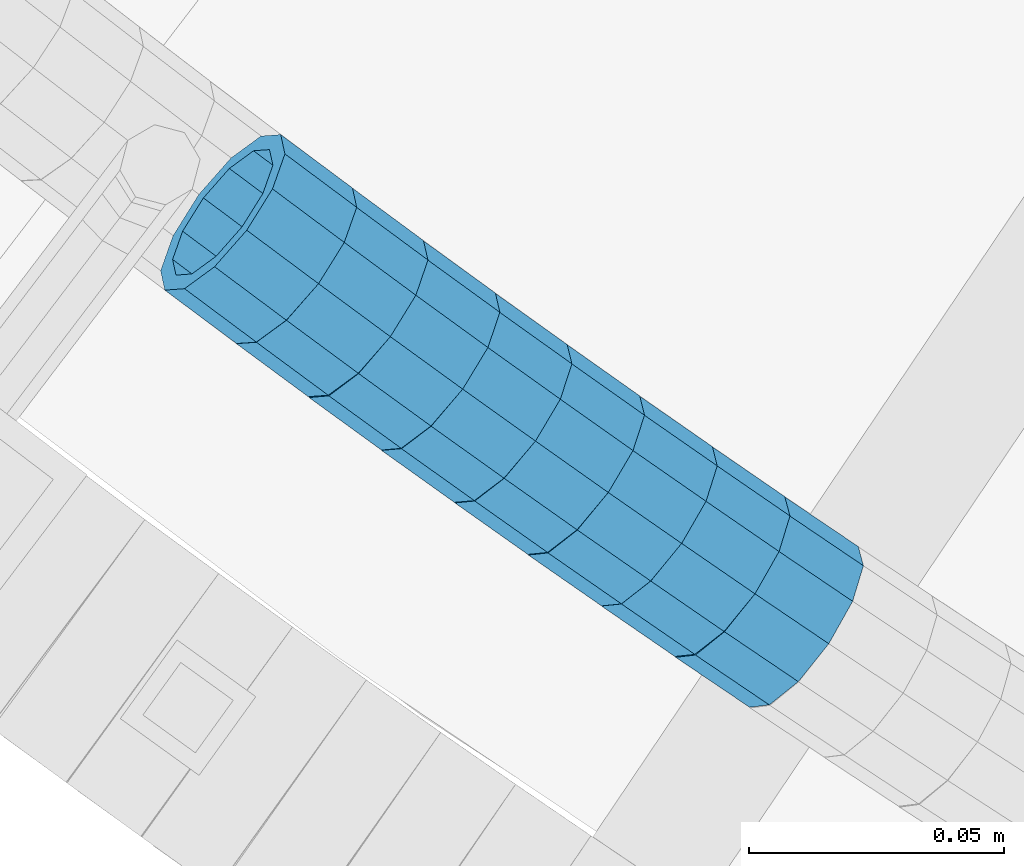
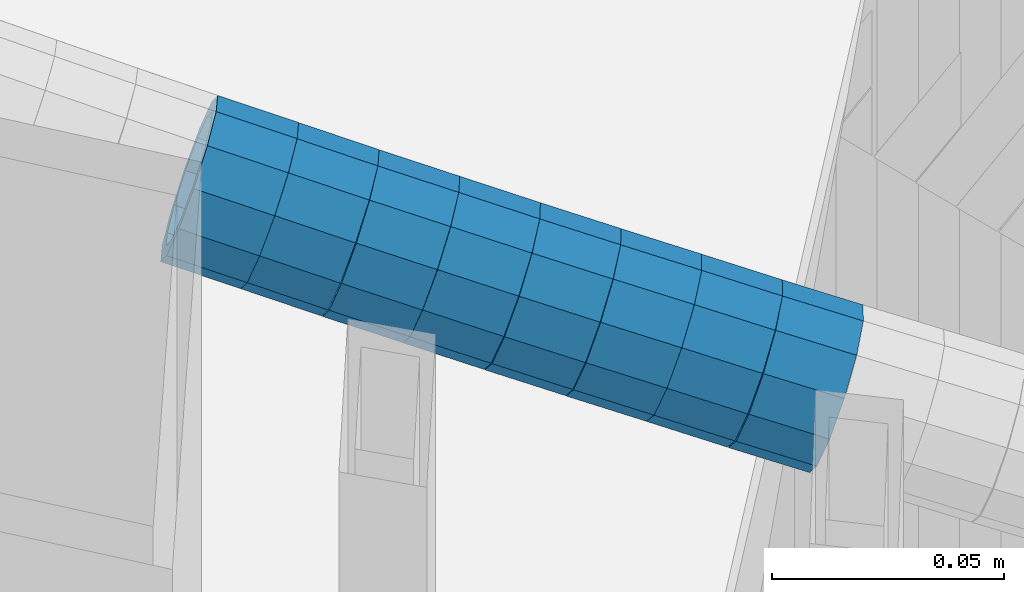
# One storey, part 644 of 975: 8 beams.
"""IFC2X3 building model written with IfcOpenShell, lengths in millimetres."""

from ifc_helpers import new_model, si_unit, frame, origin_with_axes, place, context, subcontext, project, spatial, faceted_brep, material, type_object, element, save


model = new_model("IFC2X3")

# Units and contexts
model_context = context("Model", 3, precision=1e-05, world=origin_with_axes())
body_context = subcontext(model_context, "Body", "Model", "MODEL_VIEW")
ifc_project = project(units=[si_unit("LENGTHUNIT", "METRE", prefix="MILLI"), si_unit("AREAUNIT", "SQUARE_METRE"), si_unit("VOLUMEUNIT", "CUBIC_METRE"), si_unit("MASSUNIT", "GRAM", prefix="KILO"), si_unit("TIMEUNIT", "SECOND"), si_unit("PLANEANGLEUNIT", "RADIAN"), si_unit("SOLIDANGLEUNIT", "STERADIAN"), si_unit("THERMODYNAMICTEMPERATUREUNIT", "DEGREE_CELSIUS"), si_unit("LUMINOUSINTENSITYUNIT", "LUMEN")], contexts=[model_context])

# Site, building, storey
site_placement = place(None, origin_with_axes())
site = spatial("IfcSite", under=ifc_project, at=site_placement, CompositionType="ELEMENT")
building_placement = place(site_placement, origin_with_axes())
building = spatial("IfcBuilding", under=site, at=building_placement, Name="Undefined", CompositionType="ELEMENT")
storey_placement = place(building_placement, origin_with_axes())
storey = spatial("IfcBuildingStorey", under=building, at=storey_placement, Name="Undefined", CompositionType="ELEMENT", Elevation=0.0)

# Beams
ifc_material = material()
beam_type = type_object("IfcBeamType", PredefinedType="NOTDEFINED")
beam_1_placement = place(storey_placement, frame((33062.1842327912, 1173.21661137513, 4796.37870485377), z_axis=(0.597266145727394, 0.802043110542036, 1.75857167050708e-10), x_axis=(0.762942780876697, -0.568148878908228, -0.308423676950159)))
element("IfcBeam", 1, at=beam_1_placement, inside=storey, type_object=beam_type, material=ifc_material, Name="WALL", context=body_context, shape_type="Brep", body=[
    faceted_brep([(-2.1246523829177e-07, -15.367000000002, 0.0), (-1.83998054126278e-07, -13.3082123799541, 7.68350000000009), (18.4753890351749, -13.3082123799613, 7.6835000000101), (18.4753890351676, -15.3670000000056, 0.0), (-1.06232619145885e-07, -7.68349999999919, 13.3082123799559), (18.4753890351822, -7.6835000000101, 13.3082123799686), (-3.63797880709171e-12, 3.63797880709171e-12, 15.3670000000002), (18.4753890351967, -1.2732925824821e-11, 15.3670000000238), (1.06225343188271e-07, 7.68350000000646, 13.3082123799559), (18.475389035204, 7.68349999998463, 13.3082123799832), (1.8399441614747e-07, 13.308212379965, 7.68350000000009), (18.4753890352004, 13.3082123799395, 7.68350000002465), (2.12461600312963e-07, 15.3670000000093, 0.0), (18.4753890351967, 15.3669999999838, 2.5465851649642e-11), (1.8399441614747e-07, 13.308212379965, -7.68350000000009), (18.4753890351894, 13.3082123799413, -7.68349999998463), (1.06225343188271e-07, 7.68350000000646, -13.3082123799559), (18.4753890351749, 7.68349999998827, -13.3082123799468), (-3.63797880709171e-12, 3.63797880709171e-12, -15.3670000000002), (18.4753890351676, -1.09139364212751e-11, -15.3669999999947), (-1.06232619145885e-07, -7.68349999999919, -13.3082123799559), (18.4753890351676, -7.68350000000646, -13.3082123799577), (-1.83998054126278e-07, -13.3082123799541, -7.68350000000009), (18.4753890351567, -13.3082123799613, -7.68350000000282), (-2.63386027654633e-07, -19.0500000000029, 0.0), (-2.28097633225843e-07, -16.4977839420972, -9.52499999999964), (18.4753890351567, -16.4977839420972, -9.52500000000873), (18.4753890351676, -19.0500000000065, 0.0), (-1.31691194837913e-07, -9.52500000000146, -16.4977839420935), (18.475389035164, -9.52500000000873, -16.4977839420972), (-3.63797880709171e-12, 3.63797880709171e-12, -19.0500000000002), (18.475389035164, -9.09494701772928e-12, -19.0499999999993), (1.31687556859106e-07, 9.52500000000509, -16.4977839420935), (18.4753890351822, 9.5249999999869, -16.497783942079), (2.28097633225843e-07, 16.4977839421044, -9.52499999999964), (18.4753890351931, 16.497783942079, -9.52499999997963), (2.63382389675826e-07, 19.0500000000138, 0.0), (18.475389035204, 19.0499999999847, 2.91038304567337e-11), (2.28097633225843e-07, 16.4977839421044, 9.52499999999964), (18.4753890352113, 16.4977839420753, 9.5250000000342), (1.31687556859106e-07, 9.52500000000509, 16.4977839420935), (18.475389035204, 9.52499999998327, 16.4977839421226), (-3.63797880709171e-12, 3.63797880709171e-12, 19.0500000000002), (18.4753890352004, -1.45519152283669e-11, 19.0500000000284), (-1.31691194837913e-07, -9.52500000000146, 16.4977839420935), (18.4753890351858, -9.52500000000873, 16.4977839421081), (-2.28097633225843e-07, -16.4977839420972, 9.52499999999964), (18.4753890351749, -16.4977839421008, 9.52500000000509)], [[[0, 1, 2, 3]], [[1, 4, 5, 2]], [[4, 6, 7, 5]], [[6, 8, 9, 7]], [[8, 10, 11, 9]], [[10, 12, 13, 11]], [[12, 14, 15, 13]], [[14, 16, 17, 15]], [[16, 18, 19, 17]], [[18, 20, 21, 19]], [[20, 22, 23, 21]], [[22, 0, 3, 23]], [[24, 25, 26, 27]], [[25, 28, 29, 26]], [[28, 30, 31, 29]], [[30, 32, 33, 31]], [[32, 34, 35, 33]], [[34, 36, 37, 35]], [[36, 38, 39, 37]], [[38, 40, 41, 39]], [[40, 42, 43, 41]], [[42, 44, 45, 43]], [[44, 46, 47, 45]], [[46, 24, 27, 47]], [[29, 31, 33, 35, 37, 39, 41, 43, 45, 47, 27, 26], [5, 7, 9, 11, 13, 15, 17, 19, 21, 23, 3, 2]], [[46, 44, 42, 40, 38, 36, 34, 32, 30, 28, 25, 24], [22, 20, 18, 16, 14, 12, 10, 8, 6, 4, 1, 0]]]),
])
beam_2_placement = place(storey_placement, frame((33076.1786291076, 1162.76108231139, 4790.71517758487), z_axis=(0.59358835477499, 0.804768827102243, 8.00364432507194e-11), x_axis=(0.76399482263741, -0.563513911732545, -0.314267373850863)))
element("IfcBeam", 2, at=beam_2_placement, inside=storey, type_object=beam_type, material=ifc_material, Name="WALL", context=body_context, shape_type="Brep", body=[
    faceted_brep([(-2.1246523829177e-07, -15.367000000002, 0.0), (-1.83998054126278e-07, -13.3082123799541, 7.68350000000009), (18.4599566630168, -13.3082123799522, 7.68349999999555), (18.4599566630277, -15.3670000000002, 3.63797880709171e-12), (-1.06232619145885e-07, -7.68349999999919, 13.3082123799559), (18.4599566630131, -7.68349999999373, 13.3082123799468), (-3.63797880709171e-12, 3.63797880709171e-12, 15.3670000000002), (18.4599566630059, 7.27595761418343e-12, 15.3669999999911), (1.06225343188271e-07, 7.68350000000646, 13.3082123799559), (18.4599566630059, 7.68350000000646, 13.3082123799431), (1.8399441614747e-07, 13.308212379965, 7.68350000000009), (18.4599566630131, 13.3082123799595, 7.68349999999555), (2.12461600312963e-07, 15.3670000000093, 0.0), (18.4599566630241, 15.3670000000002, 0.0), (1.8399441614747e-07, 13.308212379965, -7.68350000000009), (18.4599566630313, 13.3082123799522, -7.68349999999191), (1.06225343188271e-07, 7.68350000000646, -13.3082123799559), (18.459956663035, 7.68349999999555, -13.3082123799431), (-3.63797880709171e-12, 3.63797880709171e-12, -15.3670000000002), (18.459956663035, -3.63797880709171e-12, -15.3669999999875), (-1.06232619145885e-07, -7.68349999999919, -13.3082123799559), (18.459956663035, -7.68350000000464, -13.3082123799431), (-1.83998054126278e-07, -13.3082123799541, -7.68350000000009), (18.459956663035, -13.3082123799559, -7.68349999999191), (-2.63386027654633e-07, -19.0500000000029, 0.0), (-2.28097633225843e-07, -16.4977839420972, -9.52499999999964), (18.459956663035, -16.4977839420953, -9.5249999999869), (18.4599566630241, -19.0499999999975, 3.63797880709171e-12), (-1.31691194837913e-07, -9.52500000000146, -16.4977839420935), (18.4599566630386, -9.52500000000327, -16.497783942079), (-3.63797880709171e-12, 3.63797880709171e-12, -19.0500000000002), (18.4599566630422, -5.45696821063757e-12, -19.0499999999811), (1.31687556859106e-07, 9.52500000000509, -16.4977839420935), (18.4599566630386, 9.52499999999418, -16.497783942079), (2.28097633225843e-07, 16.4977839421044, -9.52499999999964), (18.4599566630277, 16.4977839420917, -9.52499999999418), (2.63382389675826e-07, 19.0500000000138, 0.0), (18.4599566630168, 19.0500000000011, -3.63797880709171e-12), (2.28097633225843e-07, 16.4977839421044, 9.52499999999964), (18.4599566630131, 16.4977839420972, 9.52499999999054), (1.31687556859106e-07, 9.52500000000509, 16.4977839420935), (18.4599566630095, 9.52500000000691, 16.497783942079), (-3.63797880709171e-12, 3.63797880709171e-12, 19.0500000000002), (18.4599566630059, 7.27595761418343e-12, 19.0499999999884), (-1.31691194837913e-07, -9.52500000000146, 16.4977839420935), (18.4599566630095, -9.52499999999236, 16.4977839420826), (-2.28097633225843e-07, -16.4977839420972, 9.52499999999964), (18.4599566630168, -16.4977839420881, 9.52499999999418)], [[[0, 1, 2, 3]], [[1, 4, 5, 2]], [[4, 6, 7, 5]], [[6, 8, 9, 7]], [[8, 10, 11, 9]], [[10, 12, 13, 11]], [[12, 14, 15, 13]], [[14, 16, 17, 15]], [[16, 18, 19, 17]], [[18, 20, 21, 19]], [[20, 22, 23, 21]], [[22, 0, 3, 23]], [[24, 25, 26, 27]], [[25, 28, 29, 26]], [[28, 30, 31, 29]], [[30, 32, 33, 31]], [[32, 34, 35, 33]], [[34, 36, 37, 35]], [[36, 38, 39, 37]], [[38, 40, 41, 39]], [[40, 42, 43, 41]], [[42, 44, 45, 43]], [[44, 46, 47, 45]], [[46, 24, 27, 47]], [[29, 31, 33, 35, 37, 39, 41, 43, 45, 47, 27, 26], [5, 7, 9, 11, 13, 15, 17, 19, 21, 23, 3, 2]], [[46, 44, 42, 40, 38, 36, 34, 32, 30, 28, 25, 24], [22, 20, 18, 16, 14, 12, 10, 8, 6, 4, 1, 0]]]),
])
beam_3_placement = place(storey_placement, frame((33090.3312799121, 1152.2639364768, 4784.88242879286), z_axis=(0.587154381670152, 0.80947497310636, 1.07050254882779e-10), x_axis=(0.769854095094558, -0.558415294068645, -0.309025940037997)))
element("IfcBeam", 3, at=beam_3_placement, inside=storey, type_object=beam_type, material=ifc_material, Name="WALL", context=body_context, shape_type="Brep", body=[
    faceted_brep([(-2.1246523829177e-07, -15.367000000002, 0.0), (-1.83998054126278e-07, -13.3082123799541, 7.68350000000009), (18.4537259110693, -13.3082123799595, 7.68349999998827), (18.453725911073, -15.3670000000038, 0.0), (-1.06232619145885e-07, -7.68349999999919, 13.3082123799559), (18.4537259110621, -7.683500000001, 13.3082123799431), (-3.63797880709171e-12, 3.63797880709171e-12, 15.3670000000002), (18.453725911073, -1.81898940354586e-12, 15.3669999999911), (1.06225343188271e-07, 7.68350000000646, 13.3082123799559), (18.4537259110839, 7.68349999999737, 13.3082123799504), (1.8399441614747e-07, 13.308212379965, 7.68350000000009), (18.4537259110948, 13.3082123799522, 7.68350000000646), (2.12461600312963e-07, 15.3670000000093, 0.0), (18.4537259111057, 15.3669999999947, 1.09139364212751e-11), (1.8399441614747e-07, 13.308212379965, -7.68350000000009), (18.4537259111203, 13.3082123799486, -7.68349999997372), (1.06225343188271e-07, 7.68350000000646, -13.3082123799559), (18.4537259111166, 7.68349999999373, -13.3082123799322), (-3.63797880709171e-12, 3.63797880709171e-12, -15.3670000000002), (18.4537259111094, -5.45696821063757e-12, -15.3669999999765), (-1.06232619145885e-07, -7.68349999999919, -13.3082123799559), (18.4537259111057, -7.68350000000646, -13.3082123799395), (-1.83998054126278e-07, -13.3082123799541, -7.68350000000009), (18.4537259110912, -13.3082123799595, -7.68349999999555), (-2.63386027654633e-07, -19.0500000000029, 0.0), (-2.28097633225843e-07, -16.4977839420972, -9.52499999999964), (18.4537259110839, -16.497783942099, -9.52499999999418), (18.453725911073, -19.0500000000029, -7.27595761418343e-12), (-1.31691194837913e-07, -9.52500000000146, -16.4977839420935), (18.4537259111057, -9.52500000000509, -16.497783942079), (-3.63797880709171e-12, 3.63797880709171e-12, -19.0500000000002), (18.4537259111166, -7.27595761418343e-12, -19.0499999999702), (1.31687556859106e-07, 9.52500000000509, -16.4977839420935), (18.4537259111275, 9.52499999999236, -16.4977839420608), (2.28097633225843e-07, 16.4977839421044, -9.52499999999964), (18.4537259111239, 16.4977839420881, -9.52499999997235), (2.63382389675826e-07, 19.0500000000138, 0.0), (18.4537259111057, 19.0499999999938, 1.81898940354586e-11), (2.28097633225843e-07, 16.4977839421044, 9.52499999999964), (18.4537259110948, 16.4977839420917, 9.52500000000509), (1.31687556859106e-07, 9.52500000000509, 16.4977839420935), (18.4537259110803, 9.52499999999782, 16.4977839420862), (-3.63797880709171e-12, 3.63797880709171e-12, 19.0500000000002), (18.4537259110621, -1.81898940354586e-12, 19.0499999999811), (-1.31691194837913e-07, -9.52500000000146, 16.4977839420935), (18.4537259110584, -9.52500000000146, 16.4977839420753), (-2.28097633225843e-07, -16.4977839420972, 9.52499999999964), (18.4537259110621, -16.4977839420953, 9.52499999998327)], [[[0, 1, 2, 3]], [[1, 4, 5, 2]], [[4, 6, 7, 5]], [[6, 8, 9, 7]], [[8, 10, 11, 9]], [[10, 12, 13, 11]], [[12, 14, 15, 13]], [[14, 16, 17, 15]], [[16, 18, 19, 17]], [[18, 20, 21, 19]], [[20, 22, 23, 21]], [[22, 0, 3, 23]], [[24, 25, 26, 27]], [[25, 28, 29, 26]], [[28, 30, 31, 29]], [[30, 32, 33, 31]], [[32, 34, 35, 33]], [[34, 36, 37, 35]], [[36, 38, 39, 37]], [[38, 40, 41, 39]], [[40, 42, 43, 41]], [[42, 44, 45, 43]], [[44, 46, 47, 45]], [[46, 24, 27, 47]], [[29, 31, 33, 35, 37, 39, 41, 43, 45, 47, 27, 26], [5, 7, 9, 11, 13, 15, 17, 19, 21, 23, 3, 2]], [[46, 44, 42, 40, 38, 36, 34, 32, 30, 28, 25, 24], [22, 20, 18, 16, 14, 12, 10, 8, 6, 4, 1, 0]]]),
])
beam_4_placement = place(storey_placement, frame((33104.4337809653, 1141.97598552277, 4779.21066034921), z_axis=(0.580699526806049, 0.814117964159513, 8.27240000944585e-11), x_axis=(0.773063329115919, -0.55141580108264, -0.313550161047006)))
element("IfcBeam", 4, at=beam_4_placement, inside=storey, type_object=beam_type, material=ifc_material, Name="WALL", context=body_context, shape_type="Brep", body=[
    faceted_brep([(-2.1246523829177e-07, -15.367000000002, 0.0), (-1.83998054126278e-07, -13.3082123799541, 7.68350000000009), (18.5005405327211, -13.3082123799777, 7.68350000005012), (18.5005405327393, -15.3670000000293, 6.54836185276508e-11), (-1.06232619145885e-07, -7.68349999999919, 13.3082123799559), (18.5005405326992, -7.68350000001737, 13.3082123799904), (-3.63797880709171e-12, 3.63797880709171e-12, 15.3670000000002), (18.5005405326847, -1.2732925824821e-11, 15.3670000000238), (1.06225343188271e-07, 7.68350000000646, 13.3082123799559), (18.5005405326665, 7.68349999999009, 13.308212379965), (1.8399441614747e-07, 13.308212379965, 7.68350000000009), (18.5005405326592, 13.3082123799468, 7.68349999999919), (2.12461600312963e-07, 15.3670000000093, 0.0), (18.5005405326629, 15.3669999999893, 7.27595761418343e-12), (1.8399441614747e-07, 13.308212379965, -7.68350000000009), (18.5005405326738, 13.3082123799413, -7.683499999981), (1.06225343188271e-07, 7.68350000000646, -13.3082123799559), (18.500540532692, 7.68349999997736, -13.3082123799177), (-3.63797880709171e-12, 3.63797880709171e-12, -15.3670000000002), (18.5005405327211, -2.91038304567337e-11, -15.3669999999438), (-1.06232619145885e-07, -7.68349999999919, -13.3082123799559), (18.500540532732, -7.68350000003375, -13.3082123798886), (-1.83998054126278e-07, -13.3082123799541, -7.68350000000009), (18.5005405327429, -13.3082123799886, -7.68349999992643), (-2.63386027654633e-07, -19.0500000000029, 0.0), (-2.28097633225843e-07, -16.4977839420972, -9.52499999999964), (18.5005405327502, -16.4977839421281, -9.52499999991778), (18.5005405327465, -19.0500000000338, 7.27595761418343e-11), (-1.31691194837913e-07, -9.52500000000146, -16.4977839420935), (18.5005405327429, -9.52500000003602, -16.4977839420171), (-3.63797880709171e-12, 3.63797880709171e-12, -19.0500000000002), (18.5005405327211, -3.09228198602796e-11, -19.0499999999411), (1.31687556859106e-07, 9.52500000000509, -16.4977839420935), (18.500540532692, 9.52499999997599, -16.4977839420571), (2.28097633225843e-07, 16.4977839421044, -9.52499999999964), (18.5005405326701, 16.4977839420771, -9.52499999998327), (2.63382389675826e-07, 19.0500000000138, 0.0), (18.5005405326519, 19.0499999999902, 0.0), (2.28097633225843e-07, 16.4977839421044, 9.52499999999964), (18.5005405326447, 16.4977839420881, 9.52499999999418), (1.31687556859106e-07, 9.52500000000509, 16.4977839420935), (18.5005405326556, 9.524999999996, 16.4977839420899), (-3.63797880709171e-12, 3.63797880709171e-12, 19.0500000000002), (18.5005405326738, -9.09494701772928e-12, 19.0500000000138), (-1.31691194837913e-07, -9.52500000000146, 16.4977839420935), (18.5005405327065, -9.52500000001783, 16.4977839421335), (-2.28097633225843e-07, -16.4977839420972, 9.52499999999964), (18.5005405327247, -16.497783942119, 9.52500000005602)], [[[0, 1, 2, 3]], [[1, 4, 5, 2]], [[4, 6, 7, 5]], [[6, 8, 9, 7]], [[8, 10, 11, 9]], [[10, 12, 13, 11]], [[12, 14, 15, 13]], [[14, 16, 17, 15]], [[16, 18, 19, 17]], [[18, 20, 21, 19]], [[20, 22, 23, 21]], [[22, 0, 3, 23]], [[24, 25, 26, 27]], [[25, 28, 29, 26]], [[28, 30, 31, 29]], [[30, 32, 33, 31]], [[32, 34, 35, 33]], [[34, 36, 37, 35]], [[36, 38, 39, 37]], [[38, 40, 41, 39]], [[40, 42, 43, 41]], [[42, 44, 45, 43]], [[44, 46, 47, 45]], [[46, 24, 27, 47]], [[29, 31, 33, 35, 37, 39, 41, 43, 45, 47, 27, 26], [5, 7, 9, 11, 13, 15, 17, 19, 21, 23, 3, 2]], [[46, 44, 42, 40, 38, 36, 34, 32, 30, 28, 25, 24], [22, 20, 18, 16, 14, 12, 10, 8, 6, 4, 1, 0]]]),
])
beam_5_placement = place(storey_placement, frame((33118.7793859988, 1131.70976915015, 4773.38589943369), z_axis=(0.576907432803847, 0.816809533475017, -4.64424374513327e-11), x_axis=(0.776680844071539, -0.548564792050528, -0.309586071028532)))
element("IfcBeam", 5, at=beam_5_placement, inside=storey, type_object=beam_type, material=ifc_material, Name="WALL", context=body_context, shape_type="Brep", body=[
    faceted_brep([(-2.1246523829177e-07, -15.367000000002, 0.0), (-1.83998054126278e-07, -13.3082123799541, 7.68350000000009), (18.4143965418989, -13.3082123799722, 7.68350000004284), (18.4143965419134, -15.3670000000257, 5.82076609134674e-11), (-1.06232619145885e-07, -7.68349999999919, 13.3082123799559), (18.4143965418734, -7.68350000000646, 13.3082123799759), (-3.63797880709171e-12, 3.63797880709171e-12, 15.3670000000002), (18.414396541848, 3.63797880709171e-12, 15.3669999999984), (1.06225343188271e-07, 7.68350000000646, 13.3082123799559), (18.4143965418334, 7.6835000000101, 13.3082123799395), (1.8399441614747e-07, 13.308212379965, 7.68350000000009), (18.4143965418261, 13.3082123799686, 7.68349999997736), (2.12461600312963e-07, 15.3670000000093, 0.0), (18.4143965418334, 15.3670000000093, -1.81898940354586e-11), (1.8399441614747e-07, 13.308212379965, -7.68350000000009), (18.4143965418552, 13.3082123799577, -7.68349999999919), (1.06225343188271e-07, 7.68350000000646, -13.3082123799559), (18.4143965418734, 7.68349999999191, -13.3082123799322), (-3.63797880709171e-12, 3.63797880709171e-12, -15.3670000000002), (18.4143965418989, -2.00088834390044e-11, -15.3669999999584), (-1.06232619145885e-07, -7.68349999999919, -13.3082123799559), (18.4143965419134, -7.68350000002829, -13.3082123798958), (-1.83998054126278e-07, -13.3082123799541, -7.68350000000009), (18.4143965419207, -13.3082123799832, -7.6834999999337), (-2.63386027654633e-07, -19.0500000000029, 0.0), (-2.28097633225843e-07, -16.4977839420972, -9.52499999999964), (18.4143965419316, -16.4977839421263, -9.5249999999287), (18.4143965419207, -19.0500000000284, 6.54836185276508e-11), (-1.31691194837913e-07, -9.52500000000146, -16.4977839420935), (18.4143965419207, -9.52500000003056, -16.497783942028), (-3.63797880709171e-12, 3.63797880709171e-12, -19.0500000000002), (18.4143965419025, -2.18278728425503e-11, -19.049999999952), (1.31687556859106e-07, 9.52500000000509, -16.4977839420935), (18.4143965418771, 9.52499999999054, -16.4977839420717), (2.28097633225843e-07, 16.4977839421044, -9.52499999999964), (18.414396541848, 16.4977839420972, -9.52500000000146), (2.63382389675826e-07, 19.0500000000138, 0.0), (18.4143965418298, 19.050000000012, -2.18278728425503e-11), (2.28097633225843e-07, 16.4977839421044, 9.52499999999964), (18.4143965418225, 16.4977839421117, 9.52499999997235), (1.31687556859106e-07, 9.52500000000509, 16.4977839420935), (18.4143965418225, 9.52500000001601, 16.4977839420681), (-3.63797880709171e-12, 3.63797880709171e-12, 19.0500000000002), (18.4143965418443, 7.27595761418343e-12, 19.0499999999956), (-1.31691194837913e-07, -9.52500000000146, 16.4977839420935), (18.4143965418734, -9.52500000000691, 16.4977839421153), (-2.28097633225843e-07, -16.4977839420972, 9.52499999999964), (18.4143965418989, -16.4977839421117, 9.52500000004511)], [[[0, 1, 2, 3]], [[1, 4, 5, 2]], [[4, 6, 7, 5]], [[6, 8, 9, 7]], [[8, 10, 11, 9]], [[10, 12, 13, 11]], [[12, 14, 15, 13]], [[14, 16, 17, 15]], [[16, 18, 19, 17]], [[18, 20, 21, 19]], [[20, 22, 23, 21]], [[22, 0, 3, 23]], [[24, 25, 26, 27]], [[25, 28, 29, 26]], [[28, 30, 31, 29]], [[30, 32, 33, 31]], [[32, 34, 35, 33]], [[34, 36, 37, 35]], [[36, 38, 39, 37]], [[38, 40, 41, 39]], [[40, 42, 43, 41]], [[42, 44, 45, 43]], [[44, 46, 47, 45]], [[46, 24, 27, 47]], [[29, 31, 33, 35, 37, 39, 41, 43, 45, 47, 27, 26], [5, 7, 9, 11, 13, 15, 17, 19, 21, 23, 3, 2]], [[46, 44, 42, 40, 38, 36, 34, 32, 30, 28, 25, 24], [22, 20, 18, 16, 14, 12, 10, 8, 6, 4, 1, 0]]]),
])
beam_6_placement = place(storey_placement, frame((33133.0586233052, 1121.56710709298, 4767.68347009495), z_axis=(0.570395809716058, 0.821369965520023, -2.80233507510275e-10), x_axis=(0.781121973130845, -0.542445815090811, -0.309194115051762)))
element("IfcBeam", 6, at=beam_6_placement, inside=storey, type_object=beam_type, material=ifc_material, Name="WALL", context=body_context, shape_type="Brep", body=[
    faceted_brep([(-2.1246523829177e-07, -15.367000000002, 0.0), (-1.83998054126278e-07, -13.3082123799541, 7.68350000000009), (18.4442402933746, -13.3082123799431, 7.68349999998463), (18.4442402933928, -15.3669999999893, -3.63797880709171e-12), (-1.06232619145885e-07, -7.68349999999919, 13.3082123799559), (18.4442402933564, -7.68349999998281, 13.308212379925), (-3.63797880709171e-12, 3.63797880709171e-12, 15.3670000000002), (18.4442402933455, 1.81898940354586e-11, 15.3669999999584), (1.06225343188271e-07, 7.68350000000646, 13.3082123799559), (18.4442402933419, 7.68350000001737, 13.3082123799104), (1.8399441614747e-07, 13.308212379965, 7.68350000000009), (18.4442402933528, 13.3082123799722, 7.68349999996281), (2.12461600312963e-07, 15.3670000000093, 0.0), (18.4442402933637, 15.3670000000129, -2.5465851649642e-11), (1.8399441614747e-07, 13.308212379965, -7.68350000000009), (18.4442402933855, 13.308212379965, -7.6835000000101), (1.06225343188271e-07, 7.68350000000646, -13.3082123799559), (18.4442402934037, 7.68350000000646, -13.3082123799541), (-3.63797880709171e-12, 3.63797880709171e-12, -15.3670000000002), (18.444240293411, 5.45696821063757e-12, -15.3669999999911), (-1.06232619145885e-07, -7.68349999999919, -13.3082123799559), (18.4442402934146, -7.68349999999373, -13.3082123799431), (-1.83998054126278e-07, -13.3082123799541, -7.68350000000009), (18.4442402934037, -13.3082123799468, -7.68349999999191), (-2.63386027654633e-07, -19.0500000000029, 0.0), (-2.28097633225843e-07, -16.4977839420972, -9.52499999999964), (18.444240293411, -16.4977839420862, -9.5249999999869), (18.4442402933964, -19.0499999999902, 0.0), (-1.31691194837913e-07, -9.52500000000146, -16.4977839420935), (18.4442402934219, -9.524999999996, -16.4977839420717), (-3.63797880709171e-12, 3.63797880709171e-12, -19.0500000000002), (18.4442402934183, 3.63797880709171e-12, -19.0499999999847), (1.31687556859106e-07, 9.52500000000509, -16.4977839420935), (18.4442402934073, 9.52500000000509, -16.4977839420899), (2.28097633225843e-07, 16.4977839421044, -9.52499999999964), (18.4442402933855, 16.4977839421008, -9.52500000001601), (2.63382389675826e-07, 19.0500000000138, 0.0), (18.4442402933637, 19.0500000000138, -2.91038304567337e-11), (2.28097633225843e-07, 16.4977839421044, 9.52499999999964), (18.4442402933419, 16.4977839421117, 9.52499999995052), (1.31687556859106e-07, 9.52500000000509, 16.4977839420935), (18.4442402933346, 9.52500000001965, 16.4977839420426), (-3.63797880709171e-12, 3.63797880709171e-12, 19.0500000000002), (18.4442402933346, 2.00088834390044e-11, 19.0499999999483), (-1.31691194837913e-07, -9.52500000000146, 16.4977839420935), (18.4442402933528, -9.52499999998145, 16.4977839420571), (-2.28097633225843e-07, -16.4977839420972, 9.52499999999964), (18.4442402933746, -16.497783942079, 9.52499999998327)], [[[0, 1, 2, 3]], [[1, 4, 5, 2]], [[4, 6, 7, 5]], [[6, 8, 9, 7]], [[8, 10, 11, 9]], [[10, 12, 13, 11]], [[12, 14, 15, 13]], [[14, 16, 17, 15]], [[16, 18, 19, 17]], [[18, 20, 21, 19]], [[20, 22, 23, 21]], [[22, 0, 3, 23]], [[24, 25, 26, 27]], [[25, 28, 29, 26]], [[28, 30, 31, 29]], [[30, 32, 33, 31]], [[32, 34, 35, 33]], [[34, 36, 37, 35]], [[36, 38, 39, 37]], [[38, 40, 41, 39]], [[40, 42, 43, 41]], [[42, 44, 45, 43]], [[44, 46, 47, 45]], [[46, 24, 27, 47]], [[29, 31, 33, 35, 37, 39, 41, 43, 45, 47, 27, 26], [5, 7, 9, 11, 13, 15, 17, 19, 21, 23, 3, 2]], [[46, 44, 42, 40, 38, 36, 34, 32, 30, 28, 25, 24], [22, 20, 18, 16, 14, 12, 10, 8, 6, 4, 1, 0]]]),
])
beam_7_placement = place(storey_placement, frame((33147.3516169349, 1111.60707681584, 4762.01985502168), z_axis=(0.566528823065041, 0.824041924077009, -3.30874172504992e-12), x_axis=(0.782089107823397, -0.537686261878604, -0.315008112928883)))
element("IfcBeam", 7, at=beam_7_placement, inside=storey, type_object=beam_type, material=ifc_material, Name="WALL", context=body_context, shape_type="Brep", body=[
    faceted_brep([(-2.1246523829177e-07, -15.367000000002, 0.0), (-1.83998054126278e-07, -13.3082123799541, 7.68350000000009), (18.4143965418989, -13.3082123799722, 7.68350000004284), (18.4143965419134, -15.3670000000257, 5.82076609134674e-11), (-1.06232619145885e-07, -7.68349999999919, 13.3082123799559), (18.4143965418734, -7.68350000000646, 13.3082123799759), (-3.63797880709171e-12, 3.63797880709171e-12, 15.3670000000002), (18.414396541848, 3.63797880709171e-12, 15.3669999999984), (1.06225343188271e-07, 7.68350000000646, 13.3082123799559), (18.4143965418334, 7.6835000000101, 13.3082123799395), (1.8399441614747e-07, 13.308212379965, 7.68350000000009), (18.4143965418261, 13.3082123799686, 7.68349999997736), (2.12461600312963e-07, 15.3670000000093, 0.0), (18.4143965418334, 15.3670000000093, -1.81898940354586e-11), (1.8399441614747e-07, 13.308212379965, -7.68350000000009), (18.4143965418552, 13.3082123799577, -7.68349999999919), (1.06225343188271e-07, 7.68350000000646, -13.3082123799559), (18.4143965418734, 7.68349999999191, -13.3082123799322), (-3.63797880709171e-12, 3.63797880709171e-12, -15.3670000000002), (18.4143965418989, -2.00088834390044e-11, -15.3669999999584), (-1.06232619145885e-07, -7.68349999999919, -13.3082123799559), (18.4143965419134, -7.68350000002829, -13.3082123798958), (-1.83998054126278e-07, -13.3082123799541, -7.68350000000009), (18.4143965419207, -13.3082123799832, -7.6834999999337), (-2.63386027654633e-07, -19.0500000000029, 0.0), (-2.28097633225843e-07, -16.4977839420972, -9.52499999999964), (18.4143965419316, -16.4977839421263, -9.5249999999287), (18.4143965419207, -19.0500000000284, 6.54836185276508e-11), (-1.31691194837913e-07, -9.52500000000146, -16.4977839420935), (18.4143965419207, -9.52500000003056, -16.497783942028), (-3.63797880709171e-12, 3.63797880709171e-12, -19.0500000000002), (18.4143965419025, -2.18278728425503e-11, -19.049999999952), (1.31687556859106e-07, 9.52500000000509, -16.4977839420935), (18.4143965418771, 9.52499999999054, -16.4977839420717), (2.28097633225843e-07, 16.4977839421044, -9.52499999999964), (18.414396541848, 16.4977839420972, -9.52500000000146), (2.63382389675826e-07, 19.0500000000138, 0.0), (18.4143965418298, 19.050000000012, -2.18278728425503e-11), (2.28097633225843e-07, 16.4977839421044, 9.52499999999964), (18.4143965418225, 16.4977839421117, 9.52499999997235), (1.31687556859106e-07, 9.52500000000509, 16.4977839420935), (18.4143965418225, 9.52500000001601, 16.4977839420681), (-3.63797880709171e-12, 3.63797880709171e-12, 19.0500000000002), (18.4143965418443, 7.27595761418343e-12, 19.0499999999956), (-1.31691194837913e-07, -9.52500000000146, 16.4977839420935), (18.4143965418734, -9.52500000000691, 16.4977839421153), (-2.28097633225843e-07, -16.4977839420972, 9.52499999999964), (18.4143965418989, -16.4977839421117, 9.52500000004511)], [[[0, 1, 2, 3]], [[1, 4, 5, 2]], [[4, 6, 7, 5]], [[6, 8, 9, 7]], [[8, 10, 11, 9]], [[10, 12, 13, 11]], [[12, 14, 15, 13]], [[14, 16, 17, 15]], [[16, 18, 19, 17]], [[18, 20, 21, 19]], [[20, 22, 23, 21]], [[22, 0, 3, 23]], [[24, 25, 26, 27]], [[25, 28, 29, 26]], [[28, 30, 31, 29]], [[30, 32, 33, 31]], [[32, 34, 35, 33]], [[34, 36, 37, 35]], [[36, 38, 39, 37]], [[38, 40, 41, 39]], [[40, 42, 43, 41]], [[42, 44, 45, 43]], [[44, 46, 47, 45]], [[46, 24, 27, 47]], [[29, 31, 33, 35, 37, 39, 41, 43, 45, 47, 27, 26], [5, 7, 9, 11, 13, 15, 17, 19, 21, 23, 3, 2]], [[46, 44, 42, 40, 38, 36, 34, 32, 30, 28, 25, 24], [22, 20, 18, 16, 14, 12, 10, 8, 6, 4, 1, 0]]]),
])
beam_8_placement = place(storey_placement, frame((33161.808823771, 1101.61086335199, 4756.18649456746), z_axis=(0.559963431994133, 0.828517323192069, 3.66107997251675e-11), x_axis=(0.787787563312457, -0.532435732211164, -0.309682008122822)))
element("IfcBeam", 8, at=beam_8_placement, inside=storey, type_object=beam_type, material=ifc_material, Name="WALL", context=body_context, shape_type="Brep", body=[
    faceted_brep([(-2.1246523829177e-07, -15.367000000002, 0.0), (-1.83998054126278e-07, -13.3082123799541, 7.68350000000009), (18.4143965418989, -13.3082123799722, 7.68350000004284), (18.4143965419134, -15.3670000000257, 5.82076609134674e-11), (-1.06232619145885e-07, -7.68349999999919, 13.3082123799559), (18.4143965418734, -7.68350000000646, 13.3082123799759), (-3.63797880709171e-12, 3.63797880709171e-12, 15.3670000000002), (18.414396541848, 3.63797880709171e-12, 15.3669999999984), (1.06225343188271e-07, 7.68350000000646, 13.3082123799559), (18.4143965418334, 7.6835000000101, 13.3082123799395), (1.8399441614747e-07, 13.308212379965, 7.68350000000009), (18.4143965418261, 13.3082123799686, 7.68349999997736), (2.12461600312963e-07, 15.3670000000093, 0.0), (18.4143965418334, 15.3670000000093, -1.81898940354586e-11), (1.8399441614747e-07, 13.308212379965, -7.68350000000009), (18.4143965418552, 13.3082123799577, -7.68349999999919), (1.06225343188271e-07, 7.68350000000646, -13.3082123799559), (18.4143965418734, 7.68349999999191, -13.3082123799322), (-3.63797880709171e-12, 3.63797880709171e-12, -15.3670000000002), (18.4143965418989, -2.00088834390044e-11, -15.3669999999584), (-1.06232619145885e-07, -7.68349999999919, -13.3082123799559), (18.4143965419134, -7.68350000002829, -13.3082123798958), (-1.83998054126278e-07, -13.3082123799541, -7.68350000000009), (18.4143965419207, -13.3082123799832, -7.6834999999337), (-2.63386027654633e-07, -19.0500000000029, 0.0), (-2.28097633225843e-07, -16.4977839420972, -9.52499999999964), (18.4143965419316, -16.4977839421263, -9.5249999999287), (18.4143965419207, -19.0500000000284, 6.54836185276508e-11), (-1.31691194837913e-07, -9.52500000000146, -16.4977839420935), (18.4143965419207, -9.52500000003056, -16.497783942028), (-3.63797880709171e-12, 3.63797880709171e-12, -19.0500000000002), (18.4143965419025, -2.18278728425503e-11, -19.049999999952), (1.31687556859106e-07, 9.52500000000509, -16.4977839420935), (18.4143965418771, 9.52499999999054, -16.4977839420717), (2.28097633225843e-07, 16.4977839421044, -9.52499999999964), (18.414396541848, 16.4977839420972, -9.52500000000146), (2.63382389675826e-07, 19.0500000000138, 0.0), (18.4143965418298, 19.050000000012, -2.18278728425503e-11), (2.28097633225843e-07, 16.4977839421044, 9.52499999999964), (18.4143965418225, 16.4977839421117, 9.52499999997235), (1.31687556859106e-07, 9.52500000000509, 16.4977839420935), (18.4143965418225, 9.52500000001601, 16.4977839420681), (-3.63797880709171e-12, 3.63797880709171e-12, 19.0500000000002), (18.4143965418443, 7.27595761418343e-12, 19.0499999999956), (-1.31691194837913e-07, -9.52500000000146, 16.4977839420935), (18.4143965418734, -9.52500000000691, 16.4977839421153), (-2.28097633225843e-07, -16.4977839420972, 9.52499999999964), (18.4143965418989, -16.4977839421117, 9.52500000004511)], [[[0, 1, 2, 3]], [[1, 4, 5, 2]], [[4, 6, 7, 5]], [[6, 8, 9, 7]], [[8, 10, 11, 9]], [[10, 12, 13, 11]], [[12, 14, 15, 13]], [[14, 16, 17, 15]], [[16, 18, 19, 17]], [[18, 20, 21, 19]], [[20, 22, 23, 21]], [[22, 0, 3, 23]], [[24, 25, 26, 27]], [[25, 28, 29, 26]], [[28, 30, 31, 29]], [[30, 32, 33, 31]], [[32, 34, 35, 33]], [[34, 36, 37, 35]], [[36, 38, 39, 37]], [[38, 40, 41, 39]], [[40, 42, 43, 41]], [[42, 44, 45, 43]], [[44, 46, 47, 45]], [[46, 24, 27, 47]], [[29, 31, 33, 35, 37, 39, 41, 43, 45, 47, 27, 26], [5, 7, 9, 11, 13, 15, 17, 19, 21, 23, 3, 2]], [[46, 44, 42, 40, 38, 36, 34, 32, 30, 28, 25, 24], [22, 20, 18, 16, 14, 12, 10, 8, 6, 4, 1, 0]]]),
])

save(model, "model.ifc")
